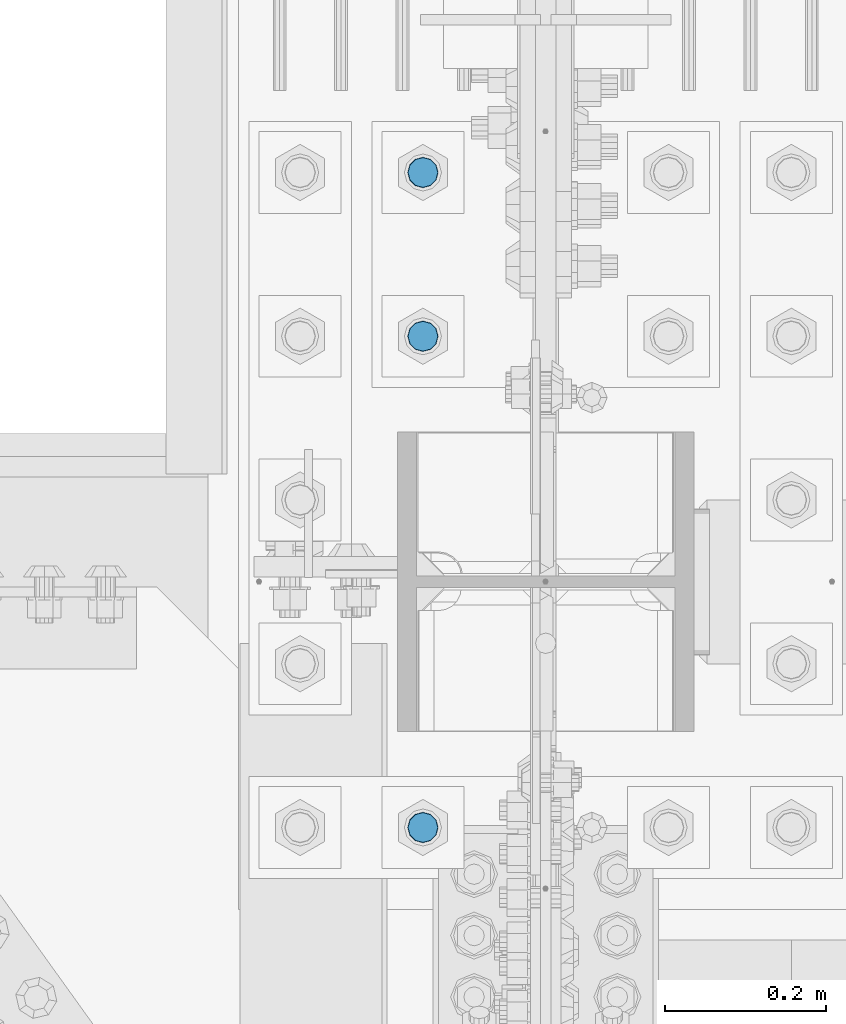
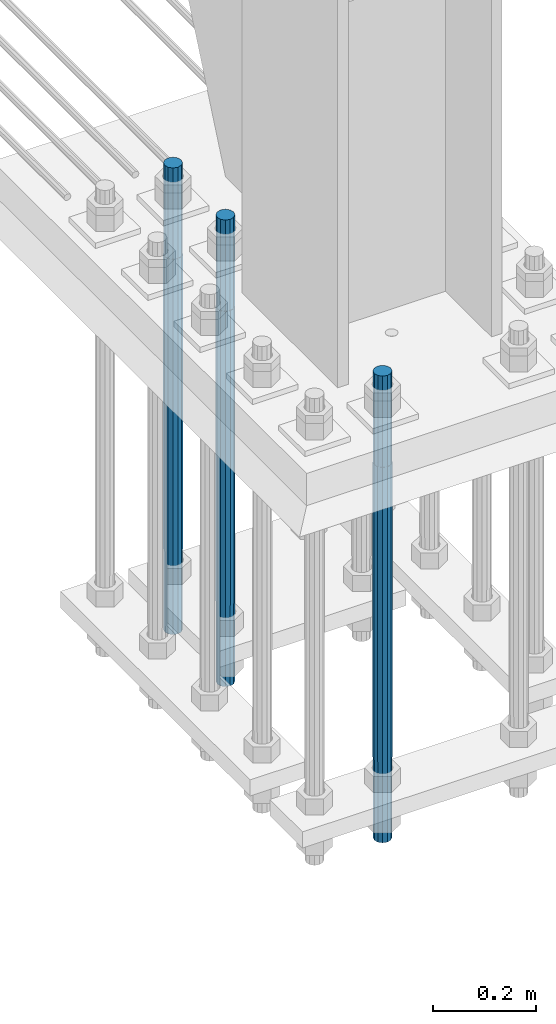
# One storey, part 1425 of 3843: 3 columns, 1 element without a shape of its own.
"""IFC2X3 building model written with IfcOpenShell, lengths in millimetres."""

import ifcopenshell
import ifcopenshell.guid

model = None  # the IFC model being written
_history = None  # IfcOwnerHistory: only IFC2X3 demands one
_inside = {}  # id of a spatial element -> (the spatial element, [elements in it])
_under = {}  # id of a project, library or spatial element -> (it, [spatial elements below it])
_declared = {}  # id of a project -> (the project, [libraries it declares])
_typed = {}  # id of a type object -> (the type object, [elements of that type])
_made_of = {}  # id of a material, layer set ... -> (it, [elements and type objects made of it])


def new_model(schema):
    """Start an empty IFC model of exactly this schema.

    Asked for "IFC4X3", IfcOpenShell would pick the latest addendum, in which some entities
    have other attributes; the version numbers below select the first issue.
    IFC2X3 requires an IfcOwnerHistory on every rooted entity: one is made here for all.
    """
    global model, _history
    if schema == "IFC4X3":
        model = ifcopenshell.file(schema_version=(4, 3, 0, 0))
    else:
        model = ifcopenshell.file(schema=schema)
    _inside.clear()
    _under.clear()
    _declared.clear()
    _typed.clear()
    _made_of.clear()
    _history = None
    if model.schema == "IFC2X3":
        org = make("IfcOrganization", Name="unknown")
        user = make(
            "IfcPersonAndOrganization",
            ThePerson=make("IfcPerson", FamilyName="unknown"),
            TheOrganization=org,
        )
        app = make(
            "IfcApplication",
            ApplicationDeveloper=org,
            Version="unknown",
            ApplicationFullName="unknown",
            ApplicationIdentifier="unknown",
        )
        _history = make(
            "IfcOwnerHistory",
            OwningUser=user,
            OwningApplication=app,
            ChangeAction="ADDED",
            CreationDate=0,
        )
    return model


def make(cls, **values):
    """One entity of the class cls with the attributes given. An attribute that is None is left unset."""
    return model.create_entity(
        cls, **{name: value for name, value in values.items() if value is not None}
    )


def rooted(cls, **values):
    """An entity with a GlobalId (a new one), such as an element, a storey or a relation."""
    return make(cls, GlobalId=ifcopenshell.guid.new(), OwnerHistory=_history, **values)


def si_unit(unit_type, name, prefix=None):
    """IfcSIUnit, for example si_unit("LENGTHUNIT", "METRE", prefix="MILLI")."""
    return make("IfcSIUnit", UnitType=unit_type, Prefix=prefix, Name=name)


def assignment(units):
    """IfcUnitAssignment: the units of a project."""
    return None if units is None else make("IfcUnitAssignment", Units=units)


def point(xyz):
    """IfcCartesianPoint."""
    return None if xyz is None else make("IfcCartesianPoint", Coordinates=xyz)


def direction(xyz):
    """IfcDirection."""
    return None if xyz is None else make("IfcDirection", DirectionRatios=xyz)


def frame(location, z_axis=None, x_axis=None):
    """IfcAxis2Placement3D, a coordinate frame: its origin and axes. An axis left out is left unset."""
    return make(
        "IfcAxis2Placement3D",
        Location=point(location),
        Axis=direction(z_axis),
        RefDirection=direction(x_axis),
    )


def origin_with_axes():
    """The frame at (0, 0, 0) with the z axis (0, 0, 1) and the x axis (1, 0, 0) written out."""
    return frame((0.0, 0.0, 0.0), z_axis=(0.0, 0.0, 1.0), x_axis=(1.0, 0.0, 0.0))


def place(relative_to, where):
    """IfcLocalPlacement: puts the frame where relative to a parent placement (None: the world)."""
    return make(
        "IfcLocalPlacement", PlacementRelTo=relative_to, RelativePlacement=where
    )


def context(
    kind, dimensions, precision=None, world=None, true_north=None, identifier=None
):
    """IfcGeometricRepresentationContext, for example the 3D "Model" context."""
    return make(
        "IfcGeometricRepresentationContext",
        ContextIdentifier=identifier,
        ContextType=kind,
        CoordinateSpaceDimension=dimensions,
        Precision=precision,
        WorldCoordinateSystem=world,
        TrueNorth=true_north,
    )


def subcontext(parent, identifier, kind, view, scale=None):
    """IfcGeometricRepresentationSubContext, for example "Body" below "Model"."""
    return make(
        "IfcGeometricRepresentationSubContext",
        ContextIdentifier=identifier,
        ContextType=kind,
        ParentContext=parent,
        TargetScale=scale,
        TargetView=view,
    )


def project(units=None, contexts=None):
    """IfcProject with its units and contexts."""
    return rooted(
        "IfcProject",
        Name="project",
        RepresentationContexts=contexts,
        UnitsInContext=assignment(units),
    )


def spatial(cls, under=None, at=None, **own):
    """A site, building, storey or space (cls), placed at a placement, below another one or the project."""
    s = rooted(cls, ObjectPlacement=at, **own)
    if under is not None:
        _under.setdefault(under.id(), (under, []))[1].append(s)
    return s


def faces_of(points, faces, orient=None, outer=None):
    """IfcFace entities. A face is a list of loops; a loop is a list of indices into points, from 0.

    orient and outer hold one flag for each loop. By default every Orientation is true, the
    first loop of a face is its IfcFaceOuterBound and the others are IfcFaceBound.
    """
    made = []
    for i, loops in enumerate(faces):
        bounds = []
        for j, loop in enumerate(loops):
            is_outer = j == 0 if outer is None else outer[i][j]
            bounds.append(
                make(
                    "IfcFaceOuterBound" if is_outer else "IfcFaceBound",
                    Bound=make("IfcPolyLoop", Polygon=[points[k] for k in loop]),
                    Orientation=True if orient is None else orient[i][j],
                )
            )
        made.append(make("IfcFace", Bounds=bounds))
    return made


def faceted_brep(points, faces, orient=None, outer=None, voids=None):
    """IfcFacetedBrep: a solid bounded by flat faces; with voids (closed shells), ...WithVoids."""
    shared = [point(p) for p in points]
    hull = make("IfcClosedShell", CfsFaces=faces_of(shared, faces, orient, outer))
    if voids is None:
        return make("IfcFacetedBrep", Outer=hull)
    return make(
        "IfcFacetedBrepWithVoids",
        Outer=hull,
        Voids=[
            make(cls, CfsFaces=faces_of(shared, fs, o, b)) for cls, fs, o, b in voids
        ],
    )


def shape(context_of_items, identifier, shape_type, items):
    """IfcShapeRepresentation: the items that make up one representation, for example the "Body"."""
    return make(
        "IfcShapeRepresentation",
        ContextOfItems=context_of_items,
        RepresentationIdentifier=identifier,
        RepresentationType=shape_type,
        Items=items,
    )


def material(Name=None, Category=None):
    """IfcMaterial."""
    return make("IfcMaterial", Name=Name, Category=Category)


def made_of(thing, what):
    """Note that an element or type object is made of a material, layer set ...; save() writes the relation."""
    if what is not None:
        _made_of.setdefault(what.id(), (what, []))[1].append(thing)
    return thing


def type_object(cls, material=None, **own):
    """A type object (cls), such as IfcWallType, which elements share."""
    return made_of(rooted(cls, **own), material)


def element(
    cls,
    number,
    at=None,
    inside=None,
    cuts=None,
    type_object=None,
    material=None,
    context=None,
    identifier="Body",
    shape_type=None,
    held_by="IfcProductDefinitionShape",
    body=None,
    shapes=None,
    **own,
):
    """One element of the class cls, such as IfcWall. Its Tag is "e" and its number.

    at: its placement. inside: the storey or other place that contains it. cuts: it is an
    opening in that element (IfcRelVoidsElement). A single representation is given by context,
    identifier, shape_type and body (its items); several are given by shapes. held_by: the class
    of the entity that holds the representations. save() writes the other relations.
    """
    e = rooted(cls, Tag="e%d" % number, ObjectPlacement=at, **own)
    if body is not None:
        shapes = [shape(context, identifier, shape_type, body)]
    if shapes is not None:
        e.Representation = make(held_by, Representations=shapes)
    if inside is not None:
        _inside.setdefault(inside.id(), (inside, []))[1].append(e)
    if cuts is not None:
        rooted(
            "IfcRelVoidsElement", RelatingBuildingElement=cuts, RelatedOpeningElement=e
        )
    if type_object is not None:
        _typed.setdefault(type_object.id(), (type_object, []))[1].append(e)
    return made_of(e, material)


def aggregate(whole, parts):
    """IfcRelAggregates: a whole, such as a stair, and the parts it consists of."""
    return rooted("IfcRelAggregates", RelatingObject=whole, RelatedObjects=parts)


def save(model, path):
    """Write the relations noted so far, then the file.

    IfcRelAggregates (storeys below a building ...), IfcRelContainedInSpatialStructure (elements
    in a storey), IfcRelDefinesByType, IfcRelAssociatesMaterial and IfcRelDeclares: one each for
    every whole, place, type object, material and project.
    """
    for whole, parts in _under.values():
        aggregate(whole, parts)
    for where, things in _inside.values():
        rooted(
            "IfcRelContainedInSpatialStructure",
            RelatedElements=things,
            RelatingStructure=where,
        )
    for kind, things in _typed.values():
        rooted("IfcRelDefinesByType", RelatedObjects=things, RelatingType=kind)
    for what, things in _made_of.values():
        rooted("IfcRelAssociatesMaterial", RelatedObjects=things, RelatingMaterial=what)
    for by, libraries in _declared.values():
        rooted("IfcRelDeclares", RelatingContext=by, RelatedDefinitions=libraries)
    model.write(path)


model = new_model("IFC2X3")

# Units and contexts
model_context = context("Model", 3, precision=1e-05, world=origin_with_axes())
body_context = subcontext(model_context, "Body", "Model", "MODEL_VIEW")
ifc_project = project(units=[si_unit("LENGTHUNIT", "METRE", prefix="MILLI"), si_unit("AREAUNIT", "SQUARE_METRE"), si_unit("VOLUMEUNIT", "CUBIC_METRE"), si_unit("MASSUNIT", "GRAM", prefix="KILO"), si_unit("TIMEUNIT", "SECOND"), si_unit("PLANEANGLEUNIT", "RADIAN"), si_unit("SOLIDANGLEUNIT", "STERADIAN"), si_unit("THERMODYNAMICTEMPERATUREUNIT", "DEGREE_CELSIUS"), si_unit("LUMINOUSINTENSITYUNIT", "LUMEN")], contexts=[model_context])

# Site, building, storey
site_placement = place(None, origin_with_axes())
site = spatial("IfcSite", under=ifc_project, at=site_placement, CompositionType="ELEMENT")
building_placement = place(site_placement, origin_with_axes())
building = spatial("IfcBuilding", under=site, at=building_placement, Name="Undefined", CompositionType="ELEMENT")
storey_placement = place(building_placement, origin_with_axes())
storey = spatial("IfcBuildingStorey", under=building, at=storey_placement, Name="Undefined", CompositionType="ELEMENT", Elevation=0.0)

# Assembly, columns
assembly_placement = place(storey_placement, origin_with_axes())
assembly = element("IfcElementAssembly", 1, at=assembly_placement, inside=storey, Name="TEMPLATE", AssemblyPlace="NOTDEFINED", PredefinedType="RIGID_FRAME")
ifc_material = material(Name="Undefined/F1554-GR.55")
column_type = type_object("IfcColumnType", PredefinedType="NOTDEFINED")
column_1_placement = place(assembly_placement, frame((85496.4, 91909.9, 29565.6), z_axis=(1.0, 0.0, 0.0), x_axis=(0.0, 0.0, -1.0)))
column_1 = element("IfcColumn", 2, at=column_1_placement, type_object=column_type, material=ifc_material, Name="ANCHOR_ROD", context=body_context, shape_type="Brep", body=[
    faceted_brep([(-215.899999999998, -16.0214699700118, 9.25), (-215.899999999998, -9.25, 16.0214699700155), (-215.899999999998, 0.0, 18.5), (-215.899999999998, 9.25, 16.0214699700155), (-215.899999999998, 16.0214699700118, 9.25), (-215.899999999998, 18.5, 0.0), (-215.899999999998, 16.0214699700118, -9.25), (-215.899999999998, 9.25, -16.0214699700155), (-215.899999999998, 0.0, -18.5), (-215.899999999998, -9.25, -16.0214699700155), (-215.899999999998, -16.0214699700118, -9.25), (-215.899999999998, -18.5, 0.0), (0.0, 18.5, 0.0), (0.0, 16.0214699700118, -9.25), (0.0, 9.25, -16.0214699700155), (0.0, 0.0, -18.5), (0.0, -9.25, -16.0214699700155), (0.0, -16.0214699700118, -9.25), (0.0, -18.5, 0.0), (0.0, -16.0214699700118, 9.25), (0.0, -9.25, 16.0214699700155), (0.0, 0.0, 18.5), (0.0, 9.25, 16.0214699700155), (0.0, 16.0214699700118, 9.25), (0.0, -16.4977839420972, 9.52500000000146), (0.0, -9.52500000000146, 16.4977839420972), (0.0, 0.0, 19.0499989999989), (0.0, 9.52500000000146, 16.4977839420972), (0.0, 16.4977839420972, 9.52500000000146), (0.0, 19.0500000000029, 0.0), (0.0, 16.4977839420972, -9.52500000000146), (0.0, 9.52500000000146, -16.4977839420972), (0.0, 0.0, -19.0499989999989), (0.0, -9.52500000000146, -16.4977839420972), (0.0, -16.4977839420972, -9.52500000000146), (0.0, -19.0500000000029, 0.0), (698.5, -19.0499999999993, 0.0), (698.5, -16.4977839420935, 9.52499999999418), (698.5, -9.52500000000146, 16.4977839420899), (698.5, 0.0, 19.0500000000029), (698.5, 9.52500000000146, 16.4977839420899), (698.5, 16.4977839420935, 9.52499999999418), (698.5, 19.0499999999993, 0.0), (698.5, 16.4977839420935, -9.52499999999418), (698.5, 9.52500000000146, -16.4977839420899), (698.5, 0.0, -19.0500000000029), (698.5, -9.52500000000146, -16.4977839420899), (698.5, -16.4977839420935, -9.52499999999418), (698.5, -9.25, 16.0214699700155), (698.5, 0.0, 18.5), (698.5, 9.25, 16.0214699700155), (698.5, 16.0214699700118, 9.25), (698.5, 18.5, 0.0), (698.5, 16.0214699700118, -9.25), (698.5, 9.25, -16.0214699700155), (698.5, 0.0, -18.5), (698.5, -9.25, -16.0214699700155), (698.5, -16.0214699700118, -9.25), (698.5, -18.5, 0.0), (698.5, -16.0214699700118, 9.25), (889.0, -9.25, -16.0214699700155), (889.0, 0.0, -18.5), (889.0, 9.25, -16.0214699700155), (889.0, 16.0214699700118, -9.25), (889.0, 18.5, 0.0), (889.0, 16.0214699700118, 9.25), (889.0, 9.25, 16.0214699700155), (889.0, 0.0, 18.5), (889.0, -9.25, 16.0214699700155), (889.0, -16.0214699700118, 9.25), (889.0, -18.5, 0.0), (889.0, -16.0214699700118, -9.25)], [[[0, 1, 2, 3, 4, 5, 6, 7, 8, 9, 10, 11]], [[6, 5, 12, 13]], [[7, 6, 13, 14]], [[8, 7, 14, 15]], [[9, 8, 15, 16]], [[10, 9, 16, 17]], [[11, 10, 17, 18]], [[0, 11, 18, 19]], [[1, 0, 19, 20]], [[2, 1, 20, 21]], [[3, 2, 21, 22]], [[4, 3, 22, 23]], [[5, 4, 23, 12]], [[24, 25, 26, 27, 28, 29, 30, 31, 32, 33, 34, 35], [22, 21, 20, 19, 18, 17, 16, 15, 14, 13, 12, 23]], [[24, 35, 36, 37]], [[25, 24, 37, 38]], [[26, 25, 38, 39]], [[27, 26, 39, 40]], [[28, 27, 40, 41]], [[29, 28, 41, 42]], [[30, 29, 42, 43]], [[31, 30, 43, 44]], [[32, 31, 44, 45]], [[33, 32, 45, 46]], [[34, 33, 46, 47]], [[35, 34, 47, 36]], [[46, 45, 44, 43, 42, 41, 40, 39, 38, 37, 36, 47], [48, 49, 50, 51, 52, 53, 54, 55, 56, 57, 58, 59]], [[60, 61, 62, 63, 64, 65, 66, 67, 68, 69, 70, 71]], [[68, 67, 49, 48]], [[69, 68, 48, 59]], [[70, 69, 59, 58]], [[71, 70, 58, 57]], [[60, 71, 57, 56]], [[61, 60, 56, 55]], [[62, 61, 55, 54]], [[63, 62, 54, 53]], [[64, 63, 53, 52]], [[65, 64, 52, 51]], [[66, 65, 51, 50]], [[67, 66, 50, 49]]]),
])
column_2_placement = place(assembly_placement, frame((85496.4, 92519.5, 29565.6), z_axis=(-1.0, 0.0, 0.0), x_axis=(0.0, 0.0, -1.0)))
column_2 = element("IfcColumn", 3, at=column_2_placement, type_object=column_type, material=ifc_material, Name="ANCHOR_ROD", context=body_context, shape_type="Brep", body=[
    faceted_brep([(-215.899999999998, -16.0214699700118, 9.25), (-215.899999999998, -9.25, 16.0214699700155), (-215.899999999998, 0.0, 18.5), (-215.899999999998, 9.25, 16.0214699700155), (-215.899999999998, 16.0214699700118, 9.25), (-215.899999999998, 18.5, 0.0), (-215.899999999998, 16.0214699700118, -9.25), (-215.899999999998, 9.25, -16.0214699700155), (-215.899999999998, 0.0, -18.5), (-215.899999999998, -9.25, -16.0214699700155), (-215.899999999998, -16.0214699700118, -9.25), (-215.899999999998, -18.5, 0.0), (0.0, 18.5, 0.0), (0.0, 16.0214699700118, -9.25), (0.0, 9.25, -16.0214699700155), (0.0, 0.0, -18.5), (0.0, -9.25, -16.0214699700155), (0.0, -16.0214699700118, -9.25), (0.0, -18.5, 0.0), (0.0, -16.0214699700118, 9.25), (0.0, -9.25, 16.0214699700155), (0.0, 0.0, 18.5), (0.0, 9.25, 16.0214699700155), (0.0, 16.0214699700118, 9.25), (0.0, -16.4977839420972, 9.52500000000146), (0.0, -9.52500000000146, 16.4977839420972), (0.0, 0.0, 19.0499989999989), (0.0, 9.52500000000146, 16.4977839420972), (0.0, 16.4977839420972, 9.52500000000146), (0.0, 19.0500000000029, 0.0), (0.0, 16.4977839420972, -9.52500000000146), (0.0, 9.52500000000146, -16.4977839420972), (0.0, 0.0, -19.0499989999989), (0.0, -9.52500000000146, -16.4977839420972), (0.0, -16.4977839420972, -9.52500000000146), (0.0, -19.0500000000029, 0.0), (698.5, -19.0499999999993, 0.0), (698.5, -16.4977839420935, 9.52499999999418), (698.5, -9.52500000000146, 16.4977839420899), (698.5, 0.0, 19.0500000000029), (698.5, 9.52500000000146, 16.4977839420899), (698.5, 16.4977839420935, 9.52499999999418), (698.5, 19.0499999999993, 0.0), (698.5, 16.4977839420935, -9.52499999999418), (698.5, 9.52500000000146, -16.4977839420899), (698.5, 0.0, -19.0500000000029), (698.5, -9.52500000000146, -16.4977839420899), (698.5, -16.4977839420935, -9.52499999999418), (698.5, -9.25, 16.0214699700155), (698.5, 0.0, 18.5), (698.5, 9.25, 16.0214699700155), (698.5, 16.0214699700118, 9.25), (698.5, 18.5, 0.0), (698.5, 16.0214699700118, -9.25), (698.5, 9.25, -16.0214699700155), (698.5, 0.0, -18.5), (698.5, -9.25, -16.0214699700155), (698.5, -16.0214699700118, -9.25), (698.5, -18.5, 0.0), (698.5, -16.0214699700118, 9.25), (889.0, -9.25, -16.0214699700155), (889.0, 0.0, -18.5), (889.0, 9.25, -16.0214699700155), (889.0, 16.0214699700118, -9.25), (889.0, 18.5, 0.0), (889.0, 16.0214699700118, 9.25), (889.0, 9.25, 16.0214699700155), (889.0, 0.0, 18.5), (889.0, -9.25, 16.0214699700155), (889.0, -16.0214699700118, 9.25), (889.0, -18.5, 0.0), (889.0, -16.0214699700118, -9.25)], [[[0, 1, 2, 3, 4, 5, 6, 7, 8, 9, 10, 11]], [[6, 5, 12, 13]], [[7, 6, 13, 14]], [[8, 7, 14, 15]], [[9, 8, 15, 16]], [[10, 9, 16, 17]], [[11, 10, 17, 18]], [[0, 11, 18, 19]], [[1, 0, 19, 20]], [[2, 1, 20, 21]], [[3, 2, 21, 22]], [[4, 3, 22, 23]], [[5, 4, 23, 12]], [[24, 25, 26, 27, 28, 29, 30, 31, 32, 33, 34, 35], [22, 21, 20, 19, 18, 17, 16, 15, 14, 13, 12, 23]], [[24, 35, 36, 37]], [[25, 24, 37, 38]], [[26, 25, 38, 39]], [[27, 26, 39, 40]], [[28, 27, 40, 41]], [[29, 28, 41, 42]], [[30, 29, 42, 43]], [[31, 30, 43, 44]], [[32, 31, 44, 45]], [[33, 32, 45, 46]], [[34, 33, 46, 47]], [[35, 34, 47, 36]], [[46, 45, 44, 43, 42, 41, 40, 39, 38, 37, 36, 47], [48, 49, 50, 51, 52, 53, 54, 55, 56, 57, 58, 59]], [[60, 61, 62, 63, 64, 65, 66, 67, 68, 69, 70, 71]], [[68, 67, 49, 48]], [[69, 68, 48, 59]], [[70, 69, 59, 58]], [[71, 70, 58, 57]], [[60, 71, 57, 56]], [[61, 60, 56, 55]], [[62, 61, 55, 54]], [[63, 62, 54, 53]], [[64, 63, 53, 52]], [[65, 64, 52, 51]], [[66, 65, 51, 50]], [[67, 66, 50, 49]]]),
])
column_3_placement = place(assembly_placement, frame((85496.4, 92722.7, 29565.6), z_axis=(-1.0, 0.0, 0.0), x_axis=(0.0, 0.0, -1.0)))
column_3 = element("IfcColumn", 4, at=column_3_placement, type_object=column_type, material=ifc_material, Name="ANCHOR_ROD", context=body_context, shape_type="Brep", body=[
    faceted_brep([(-215.899999999998, -16.0214699700118, 9.25), (-215.899999999998, -9.25, 16.0214699700155), (-215.899999999998, 0.0, 18.5), (-215.899999999998, 9.25, 16.0214699700155), (-215.899999999998, 16.0214699700118, 9.25), (-215.899999999998, 18.5, 0.0), (-215.899999999998, 16.0214699700118, -9.25), (-215.899999999998, 9.25, -16.0214699700155), (-215.899999999998, 0.0, -18.5), (-215.899999999998, -9.25, -16.0214699700155), (-215.899999999998, -16.0214699700118, -9.25), (-215.899999999998, -18.5, 0.0), (0.0, 18.5, 0.0), (0.0, 16.0214699700118, -9.25), (0.0, 9.25, -16.0214699700155), (0.0, 0.0, -18.5), (0.0, -9.25, -16.0214699700155), (0.0, -16.0214699700118, -9.25), (0.0, -18.5, 0.0), (0.0, -16.0214699700118, 9.25), (0.0, -9.25, 16.0214699700155), (0.0, 0.0, 18.5), (0.0, 9.25, 16.0214699700155), (0.0, 16.0214699700118, 9.25), (0.0, -16.4977839420972, 9.52500000000146), (0.0, -9.52500000000146, 16.4977839420972), (0.0, 0.0, 19.0499989999989), (0.0, 9.52500000000146, 16.4977839420972), (0.0, 16.4977839420972, 9.52500000000146), (0.0, 19.0500000000029, 0.0), (0.0, 16.4977839420972, -9.52500000000146), (0.0, 9.52500000000146, -16.4977839420972), (0.0, 0.0, -19.0499989999989), (0.0, -9.52500000000146, -16.4977839420972), (0.0, -16.4977839420972, -9.52500000000146), (0.0, -19.0500000000029, 0.0), (698.5, -19.0499999999993, 0.0), (698.5, -16.4977839420935, 9.52499999999418), (698.5, -9.52500000000146, 16.4977839420899), (698.5, 0.0, 19.0500000000029), (698.5, 9.52500000000146, 16.4977839420899), (698.5, 16.4977839420935, 9.52499999999418), (698.5, 19.0499999999993, 0.0), (698.5, 16.4977839420935, -9.52499999999418), (698.5, 9.52500000000146, -16.4977839420899), (698.5, 0.0, -19.0500000000029), (698.5, -9.52500000000146, -16.4977839420899), (698.5, -16.4977839420935, -9.52499999999418), (698.5, -9.25, 16.0214699700155), (698.5, 0.0, 18.5), (698.5, 9.25, 16.0214699700155), (698.5, 16.0214699700118, 9.25), (698.5, 18.5, 0.0), (698.5, 16.0214699700118, -9.25), (698.5, 9.25, -16.0214699700155), (698.5, 0.0, -18.5), (698.5, -9.25, -16.0214699700155), (698.5, -16.0214699700118, -9.25), (698.5, -18.5, 0.0), (698.5, -16.0214699700118, 9.25), (889.0, -9.25, -16.0214699700155), (889.0, 0.0, -18.5), (889.0, 9.25, -16.0214699700155), (889.0, 16.0214699700118, -9.25), (889.0, 18.5, 0.0), (889.0, 16.0214699700118, 9.25), (889.0, 9.25, 16.0214699700155), (889.0, 0.0, 18.5), (889.0, -9.25, 16.0214699700155), (889.0, -16.0214699700118, 9.25), (889.0, -18.5, 0.0), (889.0, -16.0214699700118, -9.25)], [[[0, 1, 2, 3, 4, 5, 6, 7, 8, 9, 10, 11]], [[6, 5, 12, 13]], [[7, 6, 13, 14]], [[8, 7, 14, 15]], [[9, 8, 15, 16]], [[10, 9, 16, 17]], [[11, 10, 17, 18]], [[0, 11, 18, 19]], [[1, 0, 19, 20]], [[2, 1, 20, 21]], [[3, 2, 21, 22]], [[4, 3, 22, 23]], [[5, 4, 23, 12]], [[24, 25, 26, 27, 28, 29, 30, 31, 32, 33, 34, 35], [22, 21, 20, 19, 18, 17, 16, 15, 14, 13, 12, 23]], [[24, 35, 36, 37]], [[25, 24, 37, 38]], [[26, 25, 38, 39]], [[27, 26, 39, 40]], [[28, 27, 40, 41]], [[29, 28, 41, 42]], [[30, 29, 42, 43]], [[31, 30, 43, 44]], [[32, 31, 44, 45]], [[33, 32, 45, 46]], [[34, 33, 46, 47]], [[35, 34, 47, 36]], [[46, 45, 44, 43, 42, 41, 40, 39, 38, 37, 36, 47], [48, 49, 50, 51, 52, 53, 54, 55, 56, 57, 58, 59]], [[60, 61, 62, 63, 64, 65, 66, 67, 68, 69, 70, 71]], [[68, 67, 49, 48]], [[69, 68, 48, 59]], [[70, 69, 59, 58]], [[71, 70, 58, 57]], [[60, 71, 57, 56]], [[61, 60, 56, 55]], [[62, 61, 55, 54]], [[63, 62, 54, 53]], [[64, 63, 53, 52]], [[65, 64, 52, 51]], [[66, 65, 51, 50]], [[67, 66, 50, 49]]]),
])
aggregate(assembly, [column_1, column_2, column_3])

save(model, "model.ifc")
